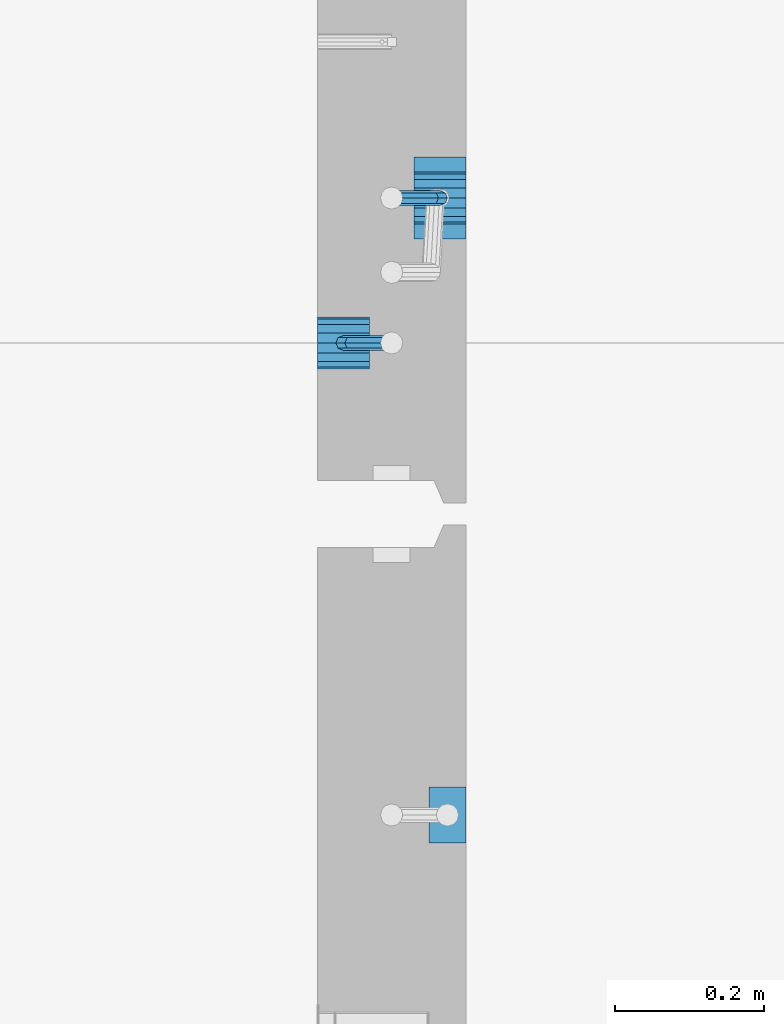
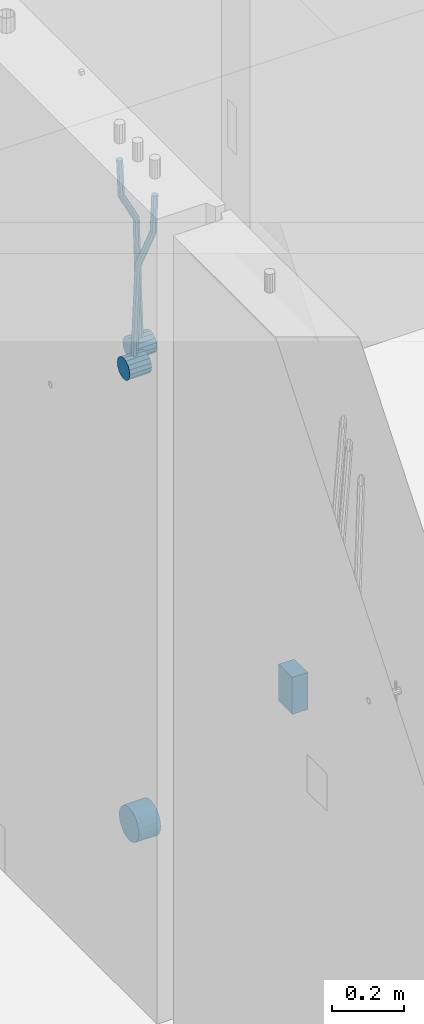
# One storey, part 128 of 325: 6 beams, 2 elements without a shape of their own.
"""IFC2X3 building model written with IfcOpenShell, lengths in millimetres."""

from ifc_helpers import new_model, si_unit, frame, origin_with_axes, place, context, subcontext, project, spatial, faceted_brep, material, type_object, element, aggregate, save


model = new_model("IFC2X3")

# Units and contexts
model_context = context("Model", 3, precision=1e-05, world=origin_with_axes())
body_context = subcontext(model_context, "Body", "Model", "MODEL_VIEW")
ifc_project = project(units=[si_unit("LENGTHUNIT", "METRE", prefix="MILLI"), si_unit("AREAUNIT", "SQUARE_METRE"), si_unit("VOLUMEUNIT", "CUBIC_METRE"), si_unit("MASSUNIT", "GRAM", prefix="KILO"), si_unit("TIMEUNIT", "SECOND"), si_unit("PLANEANGLEUNIT", "RADIAN"), si_unit("SOLIDANGLEUNIT", "STERADIAN"), si_unit("THERMODYNAMICTEMPERATUREUNIT", "DEGREE_CELSIUS"), si_unit("LUMINOUSINTENSITYUNIT", "LUMEN")], contexts=[model_context])

# Site, building, storey
site_placement = place(None, origin_with_axes())
site = spatial("IfcSite", under=ifc_project, at=site_placement, CompositionType="ELEMENT")
building_placement = place(site_placement, origin_with_axes())
building = spatial("IfcBuilding", under=site, at=building_placement, CompositionType="ELEMENT")
storey_placement = place(building_placement, origin_with_axes())
storey = spatial("IfcBuildingStorey", under=building, at=storey_placement, Name="1", CompositionType="ELEMENT", Elevation=0.0)

# Assembly, beams
assembly_1_placement = place(storey_placement, origin_with_axes())
assembly_1 = element("IfcElementAssembly", 1, at=assembly_1_placement, inside=storey, AssemblyPlace="NOTDEFINED", PredefinedType="REINFORCEMENT_UNIT")
ifc_material = material()
beam_type_1 = type_object("IfcBeamType", Name="D20", PredefinedType="NOTDEFINED")
beam_1_placement = place(assembly_1_placement, frame((21875.0000022791, 12925.0000000039, 83795.0), z_axis=(-0.999642804636942, -0.000205726999925762, -0.0267249099902983), x_axis=(-0.0267249099948371, 4.30000201934385e-08, 0.999642825806181)))
beam_1 = element("IfcBeam", 2, at=beam_1_placement, type_object=beam_type_1, material=ifc_material, Name="JM20", ObjectType="D20", context=body_context, shape_type="Brep", body=[
    faceted_brep([(0.0, -10.0, 0.0), (-4.19531716033816e-08, -7.07106781186667, -7.07106781187031), (60.4266690400545, -7.0710677960451, -7.07106780570757), (60.4266690441291, -9.99999998418934, 6.15546014159918e-09), (0.0, 0.0, -10.0), (60.426669036824, 1.58106558956206e-08, -9.99999999384454), (4.196772351861e-08, 7.07106781186303, -7.07106781186667), (60.4266690363438, 7.07106782768096, -7.07106780570757), (0.0, 10.0, 0.0), (60.4266690388904, 10.0000000158179, 6.15182216279209e-09), (4.196772351861e-08, 7.07106781185939, 7.07106781185939), (60.4266690429649, 7.07106782768096, 7.07106781802577), (0.0, 0.0, 10.0), (60.4266690461809, 1.58179318532348e-08, 10.0000000061555), (-4.19531716033816e-08, -7.07106781187031, 7.07106781185939), (60.4266690466611, -7.07106779605238, 7.07106781802213), (61.0378400410118, -7.07106779588503, -7.07106780564936), (60.991799419251, -9.99999998403655, 6.21366780251265e-09), (61.0569027789461, 1.5985278878361e-08, -9.99999999378269), (61.0378209396877, 7.07106782784831, -7.07106780564936), (60.9917724058905, 10.0000000159635, 6.21366780251265e-09), (60.9457317841297, 7.07106782781193, 7.0710678180767), (60.9266690461809, 1.59488990902901e-08, 10.0000000062028), (60.9457508854539, -7.07106779591413, 7.0710678180767), (61.6489592143771, -7.07106614513759, -7.06310863441468), (61.5568818710308, -9.9999984576425, 0.00735959856683621), (61.6870830769039, 1.71821739058942e-06, -9.99179257185824), (61.6489210170112, 7.07106947854481, -7.06310888312146), (61.556827851804, 10.0000015422847, 0.00735924683976918), (61.4647505084577, 7.07106922979438, 7.07782747982128), (61.4266266459163, 1.36643211590126e-06, 10.0065114172685), (61.464788705809, -7.07106639389531, 7.07782772852806), (176.507533210053, -7.07075588918451, -5.56719900243479), (176.415455866721, -9.9996882016876, 1.50326923053944), (176.545657072551, 0.000311974172291229, -8.49588293988199), (176.5074950126, 7.07137973449244, -5.56719925114157), (176.415401847364, 10.0003117982396, 1.50326887881965), (176.323324504032, 7.07137948574018, 8.57373711180117), (176.285200641549, 0.000311622379740584, 11.5024210492484), (176.323362701485, -7.07075613794223, 8.57373736050431), (177.027457614488, -7.07075448476826, -5.56042754518057), (176.98362511232, -9.99968666800123, 1.510669025065), (177.045614672257, 0.00031332465550804, -8.48937152882718), (177.02743930438, 7.0713811389669, -5.56042753487418), (176.983557571715, 10.0003133318824, 1.51066849724157), (176.939725069547, 7.07138115075941, 8.58176506749442), (176.921568011763, 0.000313341332002892, 11.510709051141), (176.939743379655, -7.07075447297757, 8.58176505719166), (177.547426012999, -7.07075454281949, -5.56074926635847), (177.551800786328, -9.99968673044532, 1.51031719241655), (177.545614576564, 0.000313268830723246, -8.48968089484697), (177.547427591926, 7.07138108091021, -5.56074926835936), (177.551803019262, 10.0003132695565, 1.51031718958984), (177.55617779259, 7.07138108193249, 8.58138364836122), (177.557989229041, 0.000313270278638811, 11.510315276857), (177.556176213679, -7.07075454179903, 8.58138365035848), (392.164162840534, -7.07077850405767, -5.69353954604958), (392.168537613863, -9.99971069167987, 1.37752691272544), (392.162351404098, 0.000289307596176513, -8.62247117454535), (392.164164419461, 7.07135711967385, -5.69353954804683), (392.168539846796, 10.0002893083201, 1.3775269098951), (392.17291462014, 7.07135712069794, 8.44859336867012), (392.174726056546, 0.000289309042273089, 11.3775249971586), (392.172913041213, -7.07077850303358, 8.44859337067101), (396.538434379094, -7.07077899242904, -5.69624604857745), (394.938308436409, -9.99971100091534, 1.37581316641081), (397.200953760825, 0.000288745053694583, -8.62558871992223), (396.537771713149, 7.07135663137706, -5.6962456395886), (394.937371285254, 10.0002889991902, 1.37581374480578), (393.337245342584, 7.07135699070204, 8.44787295979404), (392.674725960853, 0.000289253221126273, 11.3772156311388), (393.337908008529, -7.07077863310406, 8.44787255080519), (400.485412388065, -7.0703886450774, -3.81061000970294), (397.437518746097, -9.99946383456881, 2.56979018324637), (401.747368523298, 0.000738375370929134, -6.45357673903345), (400.484150362929, 7.07174691945329, -3.81089593960496), (397.435733973034, 10.0005360817067, 2.56938581729992), (394.387840331096, 7.07146089221351, 8.94978601024923), (393.125884195848, 0.000333871766997618, 11.5927527395797), (394.389102356217, -7.07067467231718, 8.95007194015125), (491.047211818543, -7.06143228437941, 39.4545392674409), (487.999318176604, -9.99050747387628, 45.8349394603902), (492.309167953776, 0.00969473606528481, 36.8115725381103), (491.045949793406, 7.08070328014946, 39.4542533375425), (487.997533403541, 10.0094924424029, 45.8345350944437), (484.949639761588, 7.08041725290786, 52.214935287393), (483.687683626355, 0.0092902324613533, 54.8579020167272), (484.950901786724, -7.06171831162101, 52.2152212172987), (492.034858865722, -7.06133460828096, 39.9263794605176), (490.369965797843, -9.9902730220947, 46.9674967181018), (492.760326188785, 0.00973935461115616, 37.0271096465549), (492.121398848263, 7.08080963966859, 39.968040212254), (490.492351814857, 10.0097391743966, 47.0264139182291), (488.827458746979, 7.0808007605865, 54.0675311758168), (488.101991423915, 0.00972679769074603, 56.9668009897796), (488.740918764452, -7.06134348736487, 54.0258704240805), (493.129237255765, -7.0756056976461, 39.940944555914), (492.996800490029, -10.0245278949751, 47.0024572931979), (493.26023941618, 0.00322030561801512, 37.0337629978239), (493.313067682378, 7.06526984778793, 39.9839001473629), (493.256775972521, 9.97369008520582, 47.0632056732029), (493.124339206785, 7.02476788787862, 54.1247184104868), (492.993337046384, -0.0540581153836683, 57.0318999685878), (492.940508780172, -7.1161076575554, 54.081762819038), (512.839965887761, -7.33264071613121, 40.203274884705), (512.707529122024, -10.2815629134584, 47.2647876219926), (512.970968048176, -0.253814712868916, 37.2960933266186), (513.023796314388, 6.808234829301, 40.2462304761575), (512.96750460453, 9.71665506672252, 47.3255360020012), (512.835067838794, 6.76773286939351, 54.3870487392815), (512.704065678379, -0.311093133872419, 57.2942302973788), (512.651237412181, -7.37314267604052, 54.3440931478362), (513.475233976933, -7.34092484139728, 40.211729675495), (513.36760980259, -10.2901706038756, 47.2735726438514), (513.54904646457, -0.261353064150171, 37.3037869793443), (513.545808911309, 6.80142759654882, 40.2531779482051), (513.467417831926, 9.71013601772756, 47.3321893532666), (513.359793657553, 6.76089025525107, 54.3940323216302), (513.285981169916, -0.31868152199786, 57.3019750177882), (513.289218723206, -7.38146218269685, 54.3525840489165), (514.110555848456, -7.33905210204102, 40.2199921630381), (514.027746192281, -10.2882021581954, 47.282166068373), (514.127174111025, -0.25965981985064, 37.3112858336099), (514.067866227153, 6.80296270283179, 40.2599277989102), (513.967373950843, 9.71162697813452, 47.3386435862485), (513.884564294669, 6.76247692198012, 54.4008174915798), (513.8679460321, -0.31691536021026, 57.3095238210044), (513.927253915972, -7.37953788289087, 54.3608818557041), (614.13134596184, -7.04078922407098, 41.5173702436587), (614.04853630565, -9.98993928022355, 48.5795441489936), (614.147964224409, 0.0386030581194063, 38.6086639142377), (614.088656340537, 7.10122558080184, 41.557305879538), (613.988164064242, 10.0098898561064, 48.6360216668691), (613.905354408053, 7.06073979995199, 55.698195572204), (613.888736145498, -0.0186524822402134, 58.606901901625), (613.948044029356, -7.08127500491901, 55.6582599363246)], [[[0, 1, 2, 3]], [[1, 4, 5, 2]], [[4, 6, 7, 5]], [[6, 8, 9, 7]], [[8, 10, 11, 9]], [[10, 12, 13, 11]], [[12, 14, 15, 13]], [[14, 0, 3, 15]], [[14, 12, 10, 8, 6, 4, 1, 0]], [[3, 2, 16, 17]], [[2, 5, 18, 16]], [[5, 7, 19, 18]], [[7, 9, 20, 19]], [[9, 11, 21, 20]], [[11, 13, 22, 21]], [[13, 15, 23, 22]], [[15, 3, 17, 23]], [[17, 16, 24, 25]], [[16, 18, 26, 24]], [[18, 19, 27, 26]], [[19, 20, 28, 27]], [[20, 21, 29, 28]], [[21, 22, 30, 29]], [[22, 23, 31, 30]], [[23, 17, 25, 31]], [[25, 24, 32, 33]], [[24, 26, 34, 32]], [[26, 27, 35, 34]], [[27, 28, 36, 35]], [[28, 29, 37, 36]], [[29, 30, 38, 37]], [[30, 31, 39, 38]], [[31, 25, 33, 39]], [[33, 32, 40, 41]], [[32, 34, 42, 40]], [[34, 35, 43, 42]], [[35, 36, 44, 43]], [[36, 37, 45, 44]], [[37, 38, 46, 45]], [[38, 39, 47, 46]], [[39, 33, 41, 47]], [[41, 40, 48, 49]], [[40, 42, 50, 48]], [[42, 43, 51, 50]], [[43, 44, 52, 51]], [[44, 45, 53, 52]], [[45, 46, 54, 53]], [[46, 47, 55, 54]], [[47, 41, 49, 55]], [[49, 48, 56, 57]], [[48, 50, 58, 56]], [[50, 51, 59, 58]], [[51, 52, 60, 59]], [[52, 53, 61, 60]], [[53, 54, 62, 61]], [[54, 55, 63, 62]], [[55, 49, 57, 63]], [[57, 56, 64, 65]], [[56, 58, 66, 64]], [[58, 59, 67, 66]], [[59, 60, 68, 67]], [[60, 61, 69, 68]], [[61, 62, 70, 69]], [[62, 63, 71, 70]], [[63, 57, 65, 71]], [[65, 64, 72, 73]], [[64, 66, 74, 72]], [[66, 67, 75, 74]], [[67, 68, 76, 75]], [[68, 69, 77, 76]], [[69, 70, 78, 77]], [[70, 71, 79, 78]], [[71, 65, 73, 79]], [[73, 72, 80, 81]], [[72, 74, 82, 80]], [[74, 75, 83, 82]], [[75, 76, 84, 83]], [[76, 77, 85, 84]], [[77, 78, 86, 85]], [[78, 79, 87, 86]], [[79, 73, 81, 87]], [[81, 80, 88, 89]], [[80, 82, 90, 88]], [[82, 83, 91, 90]], [[83, 84, 92, 91]], [[84, 85, 93, 92]], [[85, 86, 94, 93]], [[86, 87, 95, 94]], [[87, 81, 89, 95]], [[89, 88, 96, 97]], [[88, 90, 98, 96]], [[90, 91, 99, 98]], [[91, 92, 100, 99]], [[92, 93, 101, 100]], [[93, 94, 102, 101]], [[94, 95, 103, 102]], [[95, 89, 97, 103]], [[97, 96, 104, 105]], [[96, 98, 106, 104]], [[98, 99, 107, 106]], [[99, 100, 108, 107]], [[100, 101, 109, 108]], [[101, 102, 110, 109]], [[102, 103, 111, 110]], [[103, 97, 105, 111]], [[105, 104, 112, 113]], [[104, 106, 114, 112]], [[106, 107, 115, 114]], [[107, 108, 116, 115]], [[108, 109, 117, 116]], [[109, 110, 118, 117]], [[110, 111, 119, 118]], [[111, 105, 113, 119]], [[113, 112, 120, 121]], [[112, 114, 122, 120]], [[114, 115, 123, 122]], [[115, 116, 124, 123]], [[116, 117, 125, 124]], [[117, 118, 126, 125]], [[118, 119, 127, 126]], [[119, 113, 121, 127]], [[121, 120, 128, 129]], [[120, 122, 130, 128]], [[122, 123, 131, 130]], [[123, 124, 132, 131]], [[124, 125, 133, 132]], [[125, 126, 134, 133]], [[126, 127, 135, 134]], [[127, 121, 129, 135]], [[130, 131, 132, 133, 134, 135, 129, 128]]]),
])
beam_2_placement = place(assembly_1_placement, frame((21744.9999977209, 12729.9999999961, 83890.0), z_axis=(0.999642804629538, 0.000205762999925497, -0.0267249099901003), x_axis=(0.0267249109941254, -4.30000210532798e-08, 0.999642825779465)))
beam_2 = element("IfcBeam", 3, at=beam_2_placement, type_object=beam_type_1, material=ifc_material, Name="JM20", ObjectType="D20", context=body_context, shape_type="Brep", body=[
    faceted_brep([(0.0, -10.0, 0.0), (-4.19531716033816e-08, -7.07106781186667, -7.07106781187031), (60.4266690400545, -7.0710677960451, -7.07106780570757), (60.4266690441291, -9.99999998418934, 6.15546014159918e-09), (0.0, 0.0, -10.0), (60.426669036824, 1.58106558956206e-08, -9.99999999384454), (4.196772351861e-08, 7.07106781186303, -7.07106781186667), (60.4266690363438, 7.07106782768096, -7.07106780570757), (0.0, 10.0, 0.0), (60.4266690388904, 10.0000000158179, 6.15182216279209e-09), (4.196772351861e-08, 7.07106781185939, 7.07106781185939), (60.4266690429649, 7.07106782768096, 7.07106781802577), (0.0, 0.0, 10.0), (60.4266690461809, 1.58179318532348e-08, 10.0000000061555), (-4.19531716033816e-08, -7.07106781187031, 7.07106781185939), (60.4266690466611, -7.07106779605238, 7.07106781802213), (61.0378400410118, -7.07106779588503, -7.07106780564936), (60.991799419251, -9.99999998403655, 6.21366780251265e-09), (61.0569027789461, 1.5985278878361e-08, -9.99999999378269), (61.0378209396877, 7.07106782784831, -7.07106780564936), (60.9917724058905, 10.0000000159635, 6.21366780251265e-09), (60.9457317841297, 7.07106782781193, 7.0710678180767), (60.9266690461809, 1.59488990902901e-08, 10.0000000062028), (60.9457508854539, -7.07106779591413, 7.0710678180767), (61.6489592143771, -7.07106614513759, -7.06310863441468), (61.5568818710308, -9.9999984576425, 0.00735959856683621), (61.6870830769039, 1.71821739058942e-06, -9.99179257185824), (61.6489210170112, 7.07106947854481, -7.06310888312146), (61.556827851804, 10.0000015422847, 0.00735924683976918), (61.4647505084577, 7.07106922979438, 7.07782747982128), (61.4266266459163, 1.36643211590126e-06, 10.0065114172685), (61.464788705809, -7.07106639389531, 7.07782772852806), (176.543135720174, -7.07075579406956, -5.56673531796696), (176.451058376813, -9.99968810657447, 1.50373291501455), (176.581259582701, 0.000312069292704109, -8.49541925541052), (176.543097522794, 7.07137982961285, -5.56673556667374), (176.451004357587, 10.00031189336, 1.50373256329476), (176.35892701424, 7.07137958085514, 8.57420079627263), (176.320803151699, 0.000311717507429421, 11.5028847337162), (176.358965211621, -7.07075604281999, 8.57420104497578), (177.098753836006, -7.07075429323595, -5.55949898843028), (176.98362511232, -9.99968666800123, 1.510669025065), (177.146421932586, 0.000313595905026887, -8.48805862247536), (177.098706077581, 7.07138133041735, -5.55949936166144), (176.983557571715, 10.0003133318824, 1.51066849724157), (176.868428848029, 7.07138095712435, 8.58083651073321), (176.820760751449, 0.000313067976094317, 11.5093961447819), (176.868476606425, -7.07075466652896, 8.58083688396073), (177.654312950661, -7.07075204110879, -5.54863964998367), (177.516135294456, -9.99968450931192, 1.52107783331303), (177.711524267797, 0.000315886711177882, -8.47701274570863), (177.654255632195, 7.07138358250813, -5.54864021007961), (177.516054233929, 10.0003154905207, 1.5210770412159), (177.377876577739, 7.0713830223176, 8.59079452451624), (177.320665260588, 0.000315094497636892, 11.5191676202448), (177.377933896176, -7.07075260129932, 8.59079508461218), (297.446964549832, -7.07026642590426, -3.20709054437975), (297.308786893627, -9.99919889410376, 3.86262693891331), (297.504175866998, 0.000801501919340808, -6.13546364010836), (297.44690723141, 7.07186919770902, -3.20709110447569), (297.308705833115, 10.0008011057289, 3.86262614682164), (297.170528176895, 7.07186863752577, 10.9323436301165), (297.113316859759, 0.000800709702161839, 13.8607167258415), (297.170585495318, -7.07026698608752, 10.9323441902106), (301.63986343499, -7.07024942873613, -3.12513327486886), (299.972259732356, -9.99918809692099, 3.91468900081236), (302.330321453323, 0.000821066147182137, -6.04112849743797), (301.639172844472, 7.07188619231601, -3.12514621333321), (299.971283089879, 10.0008118992846, 3.91467070306135), (298.303679387245, 7.07187323109611, 10.9544929787371), (297.613221368898, 0.000802736216428457, 13.870488201308), (298.304369977734, -7.0702623899524, 10.9545059172033), (305.4239078393, -7.06987516590743, -1.31733741553398), (302.376014215231, -9.99895035236841, 5.06306278734701), (306.685863931343, 0.00125185327851796, -3.96030416885333), (305.422645727784, 7.07226039861052, -1.31762339341367), (302.374229320019, 10.0010495638962, 5.06265835355225), (299.326335695951, 7.07197437743162, 11.4430585564332), (298.064379603893, 0.000847358245664509, 14.0860253097508), (299.327597807453, -7.07016118708634, 11.4433445343111), (396.081143409523, -7.0609086662007, 41.9934056867296), (393.033249785469, -9.98998385266168, 48.3738058896106), (397.34309950161, 0.0102183529888862, 39.3504389334103), (396.079881298036, 7.08122689832453, 41.9931197088481), (393.031464890271, 10.0100160636066, 48.3734014558122), (389.983571266188, 7.08094087714562, 54.753801658695), (388.72161517413, 0.00981385795967071, 57.3967684120162), (389.984833377704, -7.06119468737961, 54.7540876365765), (397.068790959223, -7.06081098241702, 42.4652461198857), (395.403898118791, -9.98974938248648, 49.5063634875187), (397.79425773659, 0.0102629750217602, 39.565976041853), (397.155329851754, 7.08133326610914, 42.5069063441551), (395.526282594277, 10.0102628148125, 49.5652799416912), (393.861389753831, 7.08132441474299, 56.606397309326), (393.135922976478, 0.0102504573078477, 59.5056673873569), (393.774850861315, -7.06081983378317, 56.5647370850584), (398.163169908337, -7.0750819080713, 42.4798112226927), (398.030733605352, -10.0240038552729, 49.541324073105), (398.294170965004, 0.00374400413056719, 39.572629393122), (398.346998133013, 7.06579366763617, 42.5227662718698), (398.290705973835, 9.97421416771613, 49.6020716862276), (398.15826967085, 7.02529222051089, 56.6635845366436), (398.027268614198, -0.0535336916836968, 59.5707663662142), (397.974441446175, -7.11558335519294, 56.6206294874646), (417.87389934808, -7.33211385723553, 42.7421415616409), (417.741463045095, -10.2810358044335, 49.803654412055), (418.004900404732, -0.253287945030024, 39.8349597320685), (418.057727572756, 6.8087617184683, 42.7850966108181), (418.001435413564, 9.71718221855917, 49.8644020251777), (417.868999110593, 6.76826027135394, 56.92591487559), (417.737998053926, -0.310565640847926, 59.8330967051625), (417.685170885918, -7.37261530435353, 56.8829598264128), (418.509166047603, -7.3403978651113, 42.7505963339045), (418.401542092906, -10.2896433704191, 49.812439412166), (418.582978010687, -0.260826195415575, 39.8426533739894), (418.579739935274, 6.80195457034279, 42.7920440797316), (418.501348641992, 9.71066324766434, 49.8710553764413), (418.393724687281, 6.76141774235657, 56.9328984547028), (418.319912724211, -0.318153927339154, 59.8408414146197), (418.323150799639, -7.38093469310479, 56.8914507088775), (419.144486528079, -7.33852513420788, 42.7588588031304), (419.061676848418, -10.2876749343814, 49.821032815089), (419.161104845465, -0.25913295731516, 39.8501522177412), (419.101797015624, 6.80348967242753, 42.7987939276718), (419.00130476091, 9.71215420445515, 49.8775096098252), (418.918495081249, 6.76300440428531, 56.9396836217802), (418.901876763863, -0.316387772607413, 59.8483902071712), (418.961184593718, -7.37901040236102, 56.8997484972406), (519.165277458538, -7.04026297675227, 44.0562368946885), (519.082467778877, -9.98941277692575, 51.1184109066417), (519.181895775939, 0.0391292001404508, 41.1475303092957), (519.122587946098, 7.10175182989406, 44.0961720192245), (519.022095691384, 10.0104163619108, 51.1748877013797), (518.939286011722, 7.06126656174456, 58.2370617133347), (518.922667694336, -0.0181256151481648, 61.1457682987275), (518.981975524162, -7.08074824490541, 58.1971265887951)], [[[0, 1, 2, 3]], [[1, 4, 5, 2]], [[4, 6, 7, 5]], [[6, 8, 9, 7]], [[8, 10, 11, 9]], [[10, 12, 13, 11]], [[12, 14, 15, 13]], [[14, 0, 3, 15]], [[14, 12, 10, 8, 6, 4, 1, 0]], [[3, 2, 16, 17]], [[2, 5, 18, 16]], [[5, 7, 19, 18]], [[7, 9, 20, 19]], [[9, 11, 21, 20]], [[11, 13, 22, 21]], [[13, 15, 23, 22]], [[15, 3, 17, 23]], [[17, 16, 24, 25]], [[16, 18, 26, 24]], [[18, 19, 27, 26]], [[19, 20, 28, 27]], [[20, 21, 29, 28]], [[21, 22, 30, 29]], [[22, 23, 31, 30]], [[23, 17, 25, 31]], [[25, 24, 32, 33]], [[24, 26, 34, 32]], [[26, 27, 35, 34]], [[27, 28, 36, 35]], [[28, 29, 37, 36]], [[29, 30, 38, 37]], [[30, 31, 39, 38]], [[31, 25, 33, 39]], [[33, 32, 40, 41]], [[32, 34, 42, 40]], [[34, 35, 43, 42]], [[35, 36, 44, 43]], [[36, 37, 45, 44]], [[37, 38, 46, 45]], [[38, 39, 47, 46]], [[39, 33, 41, 47]], [[41, 40, 48, 49]], [[40, 42, 50, 48]], [[42, 43, 51, 50]], [[43, 44, 52, 51]], [[44, 45, 53, 52]], [[45, 46, 54, 53]], [[46, 47, 55, 54]], [[47, 41, 49, 55]], [[49, 48, 56, 57]], [[48, 50, 58, 56]], [[50, 51, 59, 58]], [[51, 52, 60, 59]], [[52, 53, 61, 60]], [[53, 54, 62, 61]], [[54, 55, 63, 62]], [[55, 49, 57, 63]], [[57, 56, 64, 65]], [[56, 58, 66, 64]], [[58, 59, 67, 66]], [[59, 60, 68, 67]], [[60, 61, 69, 68]], [[61, 62, 70, 69]], [[62, 63, 71, 70]], [[63, 57, 65, 71]], [[65, 64, 72, 73]], [[64, 66, 74, 72]], [[66, 67, 75, 74]], [[67, 68, 76, 75]], [[68, 69, 77, 76]], [[69, 70, 78, 77]], [[70, 71, 79, 78]], [[71, 65, 73, 79]], [[73, 72, 80, 81]], [[72, 74, 82, 80]], [[74, 75, 83, 82]], [[75, 76, 84, 83]], [[76, 77, 85, 84]], [[77, 78, 86, 85]], [[78, 79, 87, 86]], [[79, 73, 81, 87]], [[81, 80, 88, 89]], [[80, 82, 90, 88]], [[82, 83, 91, 90]], [[83, 84, 92, 91]], [[84, 85, 93, 92]], [[85, 86, 94, 93]], [[86, 87, 95, 94]], [[87, 81, 89, 95]], [[89, 88, 96, 97]], [[88, 90, 98, 96]], [[90, 91, 99, 98]], [[91, 92, 100, 99]], [[92, 93, 101, 100]], [[93, 94, 102, 101]], [[94, 95, 103, 102]], [[95, 89, 97, 103]], [[97, 96, 104, 105]], [[96, 98, 106, 104]], [[98, 99, 107, 106]], [[99, 100, 108, 107]], [[100, 101, 109, 108]], [[101, 102, 110, 109]], [[102, 103, 111, 110]], [[103, 97, 105, 111]], [[105, 104, 112, 113]], [[104, 106, 114, 112]], [[106, 107, 115, 114]], [[107, 108, 116, 115]], [[108, 109, 117, 116]], [[109, 110, 118, 117]], [[110, 111, 119, 118]], [[111, 105, 113, 119]], [[113, 112, 120, 121]], [[112, 114, 122, 120]], [[114, 115, 123, 122]], [[115, 116, 124, 123]], [[116, 117, 125, 124]], [[117, 118, 126, 125]], [[118, 119, 127, 126]], [[119, 113, 121, 127]], [[121, 120, 128, 129]], [[120, 122, 130, 128]], [[122, 123, 131, 130]], [[123, 124, 132, 131]], [[124, 125, 133, 132]], [[125, 126, 134, 133]], [[126, 127, 135, 134]], [[127, 121, 129, 135]], [[130, 131, 132, 133, 134, 135, 129, 128]]]),
])
beam_type_2 = type_object("IfcBeamType", Name="D70", PredefinedType="NOTDEFINED")
beam_3_placement = place(assembly_1_placement, frame((21910.0000022791, 12925.0, 83760.0), z_axis=(0.0, 0.0, 1.0), x_axis=(-1.0, 3.00000001838171e-08, 0.0)))
beam_3 = element("IfcBeam", 4, at=beam_3_placement, type_object=beam_type_2, material=ifc_material, ObjectType="D70", context=body_context, shape_type="Brep", body=[
    faceted_brep([(0.0, -35.0, 0.0), (0.0, -32.3357836378964, -13.3939201327739), (70.0, -32.3357836378964, -13.3939201327739), (70.0, -35.0, 0.0), (0.0, -24.7487373415279, -24.7487373415352), (70.0, -24.7487373415279, -24.7487373415352), (0.0, -13.3939201327776, -32.3357836379), (70.0, -13.3939201327776, -32.3357836379), (0.0, 0.0, -35.0), (70.0, 0.0, -35.0), (0.0, 13.3939201327776, -32.3357836379), (70.0, 13.3939201327776, -32.3357836379), (0.0, 24.7487373415279, -24.7487373415352), (70.0, 24.7487373415279, -24.7487373415352), (0.0, 32.3357836378964, -13.3939201327739), (70.0, 32.3357836378964, -13.3939201327739), (0.0, 35.0, 0.0), (70.0, 35.0, 0.0), (0.0, 32.3357836378964, 13.3939201327739), (70.0, 32.3357836378964, 13.3939201327739), (0.0, 24.7487373415279, 24.7487373415352), (70.0, 24.7487373415279, 24.7487373415352), (0.0, 13.3939201327776, 32.3357836379), (70.0, 13.3939201327776, 32.3357836379), (0.0, 0.0, 35.0), (70.0, 0.0, 35.0), (0.0, -13.3939201327776, 32.3357836379), (70.0, -13.3939201327776, 32.3357836379), (0.0, -24.7487373415279, 24.7487373415352), (70.0, -24.7487373415279, 24.7487373415352), (0.0, -32.3357836378964, 13.3939201327739), (70.0, -32.3357836378964, 13.3939201327739)], [[[0, 1, 2, 3]], [[1, 4, 5, 2]], [[4, 6, 7, 5]], [[6, 8, 9, 7]], [[8, 10, 11, 9]], [[10, 12, 13, 11]], [[12, 14, 15, 13]], [[14, 16, 17, 15]], [[16, 18, 19, 17]], [[18, 20, 21, 19]], [[20, 22, 23, 21]], [[22, 24, 25, 23]], [[24, 26, 27, 25]], [[26, 28, 29, 27]], [[28, 30, 31, 29]], [[30, 0, 3, 31]], [[5, 7, 9, 11, 13, 15, 17, 19, 21, 23, 25, 27, 29, 31, 3, 2]], [[30, 28, 26, 24, 22, 20, 18, 16, 14, 12, 10, 8, 6, 4, 1, 0]]]),
])
beam_4_placement = place(assembly_1_placement, frame((21709.9999977209, 12730.0, 83855.0), z_axis=(0.0, 0.0, 1.0), x_axis=(1.0, 0.0, 0.0)))
beam_4 = element("IfcBeam", 5, at=beam_4_placement, type_object=beam_type_2, material=ifc_material, ObjectType="D70", context=body_context, shape_type="Brep", body=[
    faceted_brep([(0.0, -35.0, 0.0), (0.0, -32.3357836378964, -13.3939201327739), (70.0, -32.3357836378964, -13.3939201327739), (70.0, -35.0, 0.0), (0.0, -24.7487373415279, -24.7487373415352), (70.0, -24.7487373415279, -24.7487373415352), (0.0, -13.3939201327776, -32.3357836379), (70.0, -13.3939201327776, -32.3357836379), (0.0, 0.0, -35.0), (70.0, 0.0, -35.0), (0.0, 13.3939201327776, -32.3357836379), (70.0, 13.3939201327776, -32.3357836379), (0.0, 24.7487373415279, -24.7487373415352), (70.0, 24.7487373415279, -24.7487373415352), (0.0, 32.3357836378964, -13.3939201327739), (70.0, 32.3357836378964, -13.3939201327739), (0.0, 35.0, 0.0), (70.0, 35.0, 0.0), (0.0, 32.3357836378964, 13.3939201327739), (70.0, 32.3357836378964, 13.3939201327739), (0.0, 24.7487373415279, 24.7487373415352), (70.0, 24.7487373415279, 24.7487373415352), (0.0, 13.3939201327776, 32.3357836379), (70.0, 13.3939201327776, 32.3357836379), (0.0, 0.0, 35.0), (70.0, 0.0, 35.0), (0.0, -13.3939201327776, 32.3357836379), (70.0, -13.3939201327776, 32.3357836379), (0.0, -24.7487373415279, 24.7487373415352), (70.0, -24.7487373415279, 24.7487373415352), (0.0, -32.3357836378964, 13.3939201327739), (70.0, -32.3357836378964, 13.3939201327739)], [[[0, 1, 2, 3]], [[1, 4, 5, 2]], [[4, 6, 7, 5]], [[6, 8, 9, 7]], [[8, 10, 11, 9]], [[10, 12, 13, 11]], [[12, 14, 15, 13]], [[14, 16, 17, 15]], [[16, 18, 19, 17]], [[18, 20, 21, 19]], [[20, 22, 23, 21]], [[22, 24, 25, 23]], [[24, 26, 27, 25]], [[26, 28, 29, 27]], [[28, 30, 31, 29]], [[30, 0, 3, 31]], [[5, 7, 9, 11, 13, 15, 17, 19, 21, 23, 25, 27, 29, 31, 3, 2]], [[30, 28, 26, 24, 22, 20, 18, 16, 14, 12, 10, 8, 6, 4, 1, 0]]]),
])
beam_type_3 = type_object("IfcBeamType", Name="D110", PredefinedType="NOTDEFINED")
beam_5_placement = place(assembly_1_placement, frame((21910.0000022791, 12925.0, 82155.0), z_axis=(0.0, 0.0, 1.0), x_axis=(-1.0, 3.00000001838171e-08, 0.0)))
beam_5 = element("IfcBeam", 6, at=beam_5_placement, type_object=beam_type_3, material=ifc_material, ObjectType="D110", context=body_context, shape_type="Brep", body=[
    faceted_brep([(0.0, -55.0, 0.0), (0.0, -52.3081083962352, -16.9959346906253), (70.0, -52.3081083962352, -16.9959346906253), (70.0, -55.0, 0.0), (0.0, -44.4959346906217, -32.328188876083), (70.0, -44.4959346906217, -32.328188876083), (0.0, -32.3281888760866, -44.4959346906253), (70.0, -32.3281888760866, -44.4959346906253), (0.0, -16.9959346906217, -52.3081083962315), (70.0, -16.9959346906217, -52.3081083962315), (0.0, 0.0, -55.0), (70.0, 0.0, -55.0), (0.0, 16.9959346906217, -52.3081083962315), (70.0, 16.9959346906217, -52.3081083962315), (0.0, 32.3281888760866, -44.4959346906253), (70.0, 32.3281888760866, -44.4959346906253), (0.0, 44.4959346906217, -32.328188876083), (70.0, 44.4959346906217, -32.328188876083), (0.0, 52.3081083962352, -16.9959346906253), (70.0, 52.3081083962352, -16.9959346906253), (0.0, 55.0, 0.0), (70.0, 55.0, 0.0), (0.0, 52.3081083962352, 16.9959346906253), (70.0, 52.3081083962352, 16.9959346906253), (0.0, 44.4959346906217, 32.328188876083), (70.0, 44.4959346906217, 32.328188876083), (0.0, 32.3281888760866, 44.4959346906253), (70.0, 32.3281888760866, 44.4959346906253), (0.0, 16.9959346906217, 52.3081083962315), (70.0, 16.9959346906217, 52.3081083962315), (0.0, 0.0, 55.0), (70.0, 0.0, 55.0), (0.0, -16.9959346906217, 52.3081083962315), (70.0, -16.9959346906217, 52.3081083962315), (0.0, -32.3281888760866, 44.4959346906253), (70.0, -32.3281888760866, 44.4959346906253), (0.0, -44.4959346906217, 32.328188876083), (70.0, -44.4959346906217, 32.328188876083), (0.0, -52.3081083962352, 16.9959346906253), (70.0, -52.3081083962352, 16.9959346906253)], [[[0, 1, 2, 3]], [[1, 4, 5, 2]], [[4, 6, 7, 5]], [[6, 8, 9, 7]], [[8, 10, 11, 9]], [[10, 12, 13, 11]], [[12, 14, 15, 13]], [[14, 16, 17, 15]], [[16, 18, 19, 17]], [[18, 20, 21, 19]], [[20, 22, 23, 21]], [[22, 24, 25, 23]], [[24, 26, 27, 25]], [[26, 28, 29, 27]], [[28, 30, 31, 29]], [[30, 32, 33, 31]], [[32, 34, 35, 33]], [[34, 36, 37, 35]], [[36, 38, 39, 37]], [[38, 0, 3, 39]], [[5, 7, 9, 11, 13, 15, 17, 19, 21, 23, 25, 27, 29, 31, 33, 35, 37, 39, 3, 2]], [[38, 36, 34, 32, 30, 28, 26, 24, 22, 20, 18, 16, 14, 12, 10, 8, 6, 4, 1, 0]]]),
])
aggregate(assembly_1, [beam_1, beam_3, beam_2, beam_4, beam_5])

# Assembly, beam
assembly_2_placement = place(storey_placement, origin_with_axes())
assembly_2 = element("IfcElementAssembly", 7, at=assembly_2_placement, inside=storey, AssemblyPlace="NOTDEFINED", PredefinedType="REINFORCEMENT_UNIT")
beam_type_4 = type_object("IfcBeamType", Name="125X50", PredefinedType="NOTDEFINED")
beam_6_placement = place(assembly_2_placement, frame((21885.0, 12057.5, 83105.0), z_axis=(0.0, 0.0, 1.0), x_axis=(0.0, 1.0, 0.0)))
beam_6 = element("IfcBeam", 8, at=beam_6_placement, type_object=beam_type_4, material=ifc_material, Name="WM1", ObjectType="125X50", context=body_context, shape_type="Brep", body=[
    faceted_brep([(0.0, 25.0, -62.5), (0.0, 25.0, 62.5), (75.0, 25.0, 62.5), (75.0, 25.0, -62.5), (0.0, -25.0, 62.5), (75.0, -25.0, 62.5), (0.0, -25.0, -62.5), (75.0, -25.0, -62.5)], [[[0, 1, 2, 3]], [[1, 4, 5, 2]], [[4, 6, 7, 5]], [[6, 0, 3, 7]], [[5, 7, 3, 2]], [[0, 6, 4, 1]]]),
])
aggregate(assembly_2, [beam_6])

save(model, "model.ifc")
